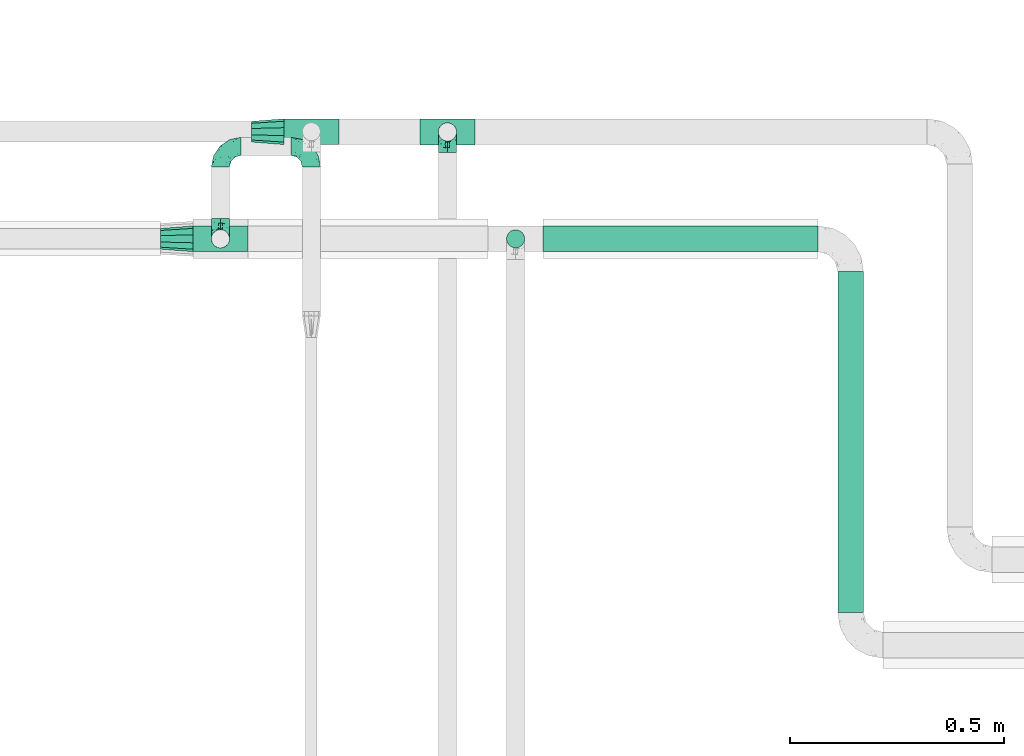
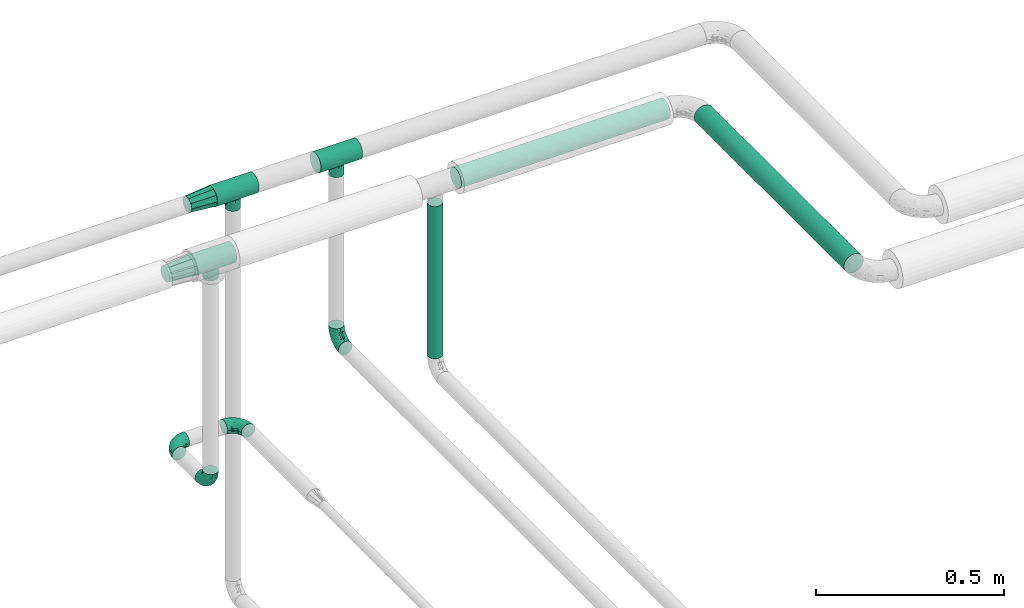
# One storey, part 581 of 827: 9 flow fittings, 3 flow segments.
"""IFC2X3 building model written with IfcOpenShell, lengths in millimetres."""

from ifc_helpers import new_model, entity, si_unit, converted_unit, derived_unit, direction, frame, origin, origin_2d_with_axis, place, context, subcontext, project, spatial, circle, extrude, faceted_brep, source, transform, mapped, material, type_object, type_shapes, element, save


model = new_model("IFC2X3")

# Units and contexts
model_context = context("Model", 3, precision=0.01, world=origin(), true_north=direction((6.12303176911189e-17, 1.0)))
body_context = subcontext(model_context, "Body", "Model", "MODEL_VIEW")
ifc_project = project(units=[si_unit("LENGTHUNIT", "METRE", prefix="MILLI"), si_unit("AREAUNIT", "SQUARE_METRE"), si_unit("VOLUMEUNIT", "CUBIC_METRE"), converted_unit("PLANEANGLEUNIT", "DEGREE", entity("IfcRatioMeasure", 0.0174532925199433), si_unit("PLANEANGLEUNIT", "RADIAN"), dimensions=[0, 0, 0, 0, 0, 0, 0]), si_unit("MASSUNIT", "GRAM", prefix="KILO"), derived_unit("MASSDENSITYUNIT", [(si_unit("MASSUNIT", "GRAM", prefix="KILO"), 1), (si_unit("LENGTHUNIT", "METRE"), -3)]), derived_unit("MOMENTOFINERTIAUNIT", [(si_unit("LENGTHUNIT", "METRE"), 4)]), si_unit("TIMEUNIT", "SECOND"), si_unit("FREQUENCYUNIT", "HERTZ"), si_unit("THERMODYNAMICTEMPERATUREUNIT", "DEGREE_CELSIUS"), derived_unit("THERMALTRANSMITTANCEUNIT", [(si_unit("MASSUNIT", "GRAM", prefix="KILO"), 1), (si_unit("THERMODYNAMICTEMPERATUREUNIT", "KELVIN"), -1), (si_unit("TIMEUNIT", "SECOND"), -3)]), derived_unit("VOLUMETRICFLOWRATEUNIT", [(si_unit("LENGTHUNIT", "METRE"), 3), (si_unit("TIMEUNIT", "SECOND"), -1)]), derived_unit("MASSFLOWRATEUNIT", [(si_unit("MASSUNIT", "GRAM", prefix="KILO"), 1), (si_unit("TIMEUNIT", "SECOND"), -1)]), derived_unit("ROTATIONALFREQUENCYUNIT", [(si_unit("TIMEUNIT", "SECOND"), -1)]), si_unit("ELECTRICCURRENTUNIT", "AMPERE"), si_unit("ELECTRICVOLTAGEUNIT", "VOLT"), si_unit("POWERUNIT", "WATT"), si_unit("FORCEUNIT", "NEWTON", prefix="KILO"), si_unit("ILLUMINANCEUNIT", "LUX"), si_unit("LUMINOUSFLUXUNIT", "LUMEN"), si_unit("LUMINOUSINTENSITYUNIT", "CANDELA"), derived_unit("USERDEFINED", [(si_unit("MASSUNIT", "GRAM", prefix="KILO"), -1), (si_unit("LENGTHUNIT", "METRE"), -2), (si_unit("TIMEUNIT", "SECOND"), 3), (si_unit("LUMINOUSFLUXUNIT", "LUMEN"), 1)]), derived_unit("LINEARVELOCITYUNIT", [(si_unit("LENGTHUNIT", "METRE"), 1), (si_unit("TIMEUNIT", "SECOND"), -1)]), si_unit("PRESSUREUNIT", "PASCAL"), derived_unit("USERDEFINED", [(si_unit("LENGTHUNIT", "METRE"), -2), (si_unit("MASSUNIT", "GRAM", prefix="KILO"), 1), (si_unit("TIMEUNIT", "SECOND"), -2)]), derived_unit("LINEARFORCEUNIT", [(si_unit("MASSUNIT", "GRAM", prefix="KILO"), 1), (si_unit("LENGTHUNIT", "METRE"), 1), (si_unit("TIMEUNIT", "SECOND"), -2), (si_unit("LENGTHUNIT", "METRE"), -1)]), derived_unit("PLANARFORCEUNIT", [(si_unit("MASSUNIT", "GRAM", prefix="KILO"), 1), (si_unit("LENGTHUNIT", "METRE"), 1), (si_unit("TIMEUNIT", "SECOND"), -2), (si_unit("LENGTHUNIT", "METRE"), -2)])], contexts=[model_context])

# Site, building, storey
site_placement = place(None, origin())
site = spatial("IfcSite", under=ifc_project, at=site_placement, CompositionType="ELEMENT")
building_placement = place(site_placement, origin())
building = spatial("IfcBuilding", under=site, at=building_placement, CompositionType="ELEMENT")
storey_placement = place(building_placement, frame((0.0, 0.0, 28200.0)))
storey = spatial("IfcBuildingStorey", under=building, at=storey_placement, Name="08", CompositionType="ELEMENT", Elevation=28200.0)

# Flow segments
pipe_segment_type = type_object("IfcPipeSegmentType", PredefinedType="NOTDEFINED")
flow_segment_1_placement = place(storey_placement, frame((15824.94, 18731.38, 2968.4)))
element("IfcFlowSegment", 1, at=flow_segment_1_placement, inside=storey, type_object=pipe_segment_type, context=body_context, shape_type="SweptSolid", body=[
    extrude(circle(Radius=30.0, at=origin_2d_with_axis()), frame((0.0, 31.6, 31.6), z_axis=(1.0, 0.0, 0.0), x_axis=(0.0, -1.0, 0.0)), (0.0, 0.0, 1.0), 643.229003793408),
])
flow_segment_2_placement = place(storey_placement, frame((16512.58, 17888.97, 2968.4)))
element("IfcFlowSegment", 2, at=flow_segment_2_placement, inside=storey, type_object=pipe_segment_type, context=body_context, shape_type="SweptSolid", body=[
    extrude(circle(Radius=30.0, at=origin_2d_with_axis()), frame((31.6, 0.0, 31.6), z_axis=(0.0, 1.0, 0.0), x_axis=(-1.0, 0.0, 0.0)), (0.0, 0.0, 1.0), 798.000000000022),
])
flow_segment_3_placement = place(storey_placement, frame((15738.2, 18740.23, 2448.01)))
element("IfcFlowSegment", 3, at=flow_segment_3_placement, inside=storey, type_object=pipe_segment_type, context=body_context, shape_type="SweptSolid", body=[
    extrude(circle(Radius=21.15, at=origin_2d_with_axis()), frame((22.75, 22.75, 0.0)), (0.0, 0.0, 1.0), 494.989664275865),
])

# Flow fittings
ifc_material = material()
pipe_fitting_type_1 = type_object("IfcPipeFittingType", Name="ADSK_1", PredefinedType="NOTDEFINED", material=ifc_material)
shared_shape_1 = source(origin(), body_context, "Body", "Brep", [
    faceted_brep([(-48.0, 10.6, -18.36), (-48.0, 5.49, -20.48), (-48.0, 0.0, -21.2), (-48.0, -5.49, -20.48), (-48.0, -10.6, -18.36), (-48.0, -14.99, -14.99), (-48.0, -18.36, -10.6), (-48.0, -20.48, -5.49), (-48.0, -21.2, 0.0), (-48.0, -20.48, 5.49), (-48.0, -18.36, 10.6), (-48.0, -14.99, 14.99), (-48.0, -10.6, 18.36), (-48.0, -5.49, 20.48), (-48.0, 0.0, 21.2), (-48.0, 5.49, 20.48), (-48.0, 10.6, 18.36), (-48.0, 14.99, 14.99), (-48.0, 18.36, 10.6), (-48.0, 20.48, 5.49), (-48.0, 21.2, 0.0), (-48.0, 20.48, -5.49), (-48.0, 18.36, -10.6), (-48.0, 14.99, -14.99), (0.0, 48.0, -21.2), (-5.49, 48.0, -20.48), (-10.6, 48.0, -18.36), (-14.99, 48.0, -14.99), (-18.36, 48.0, -10.6), (-20.48, 48.0, -5.49), (-21.2, 48.0, 0.0), (-20.48, 48.0, 5.49), (-18.36, 48.0, 10.6), (-14.99, 48.0, 14.99), (-10.6, 48.0, 18.36), (-5.49, 48.0, 20.48), (0.0, 48.0, 21.2), (5.49, 48.0, 20.48), (10.6, 48.0, 18.36), (14.99, 48.0, 14.99), (18.36, 48.0, 10.6), (20.48, 48.0, 5.49), (21.2, 48.0, 0.0), (20.48, 48.0, -5.49), (18.36, 48.0, -10.6), (14.99, 48.0, -14.99), (10.6, 48.0, -18.36), (5.49, 48.0, -20.48), (-35.25, -16.22, 12.01), (-34.76, -18.57, 0.0), (-20.87, -12.37, 10.9), (-31.49, -11.78, 15.9), (-37.0, -2.58, 20.86), (-33.89, 3.62, 21.15), (-31.81, -18.14, 6.76), (-5.78, 5.78, 17.67), (-19.42, -4.1, 17.86), (-9.6, -3.39, 13.73), (-35.44, -7.73, 19.13), (11.78, 31.49, 15.9), (-5.93, -5.46, 6.95), (-18.45, -13.78, 5.46), (-10.29, -8.43, 0.0), (-24.6, 0.55, 20.62), (-37.28, 17.94, 13.81), (-33.38, 22.85, 9.59), (-41.46, 20.06, 8.75), (-29.51, 20.45, 15.16), (-15.04, 10.79, 21.13), (-7.08, 16.98, 20.93), (-8.39, 23.51, 21.15), (-40.86, 13.03, 17.26), (-8.05, 41.26, 19.83), (-3.21, 35.97, 21.14), (8.53, 19.66, 14.74), (4.1, 19.42, 17.86), (-37.72, 22.66, 4.78), (-37.07, 8.58, 19.98), (-13.0, 5.43, 19.97), (-3.78, 13.93, 19.7), (3.02, 8.69, 13.43), (-2.27, -0.05, 10.65), (6.22, 6.99, 7.09), (-22.25, 34.6, 9.45), (18.14, 31.81, 6.76), (16.22, 35.25, 12.01), (12.37, 20.87, 10.9), (7.73, 35.44, 19.13), (-21.52, -15.93, 0.0), (2.58, 37.0, 20.86), (18.57, 34.76, 0.0), (13.78, 18.45, 5.46), (15.93, 21.52, 0.0), (-20.03, -8.54, 14.9), (-28.6, 28.6, 5.16), (-24.79, 34.6, 0.0), (-34.6, 24.79, 0.0), (-22.81, 37.41, 4.68), (-23.36, 26.33, 14.79), (-13.68, 37.05, 17.49), (-17.72, 38.12, 13.73), (-26.25, 27.3, 11.24), (-9.71, 32.34, 20.14), (-17.26, 25.6, 18.71), (-26.33, 9.99, 20.77), (-24.06, 6.05, 21.2), (-25.02, 15.46, 19.56), (-24.3, 20.72, 17.57), (-31.95, 15.23, 17.8), (-13.53, 24.7, 20.21), (-17.6, 17.6, 20.6), (-0.55, 24.6, 20.62), (-11.41, -7.48, 10.43), (0.93, -0.93, 0.0), (8.43, 10.29, 0.0), (-11.41, -7.48, -10.43), (-20.1, -8.84, -14.66), (-9.6, -3.39, -13.73), (7.73, 35.44, -19.13), (4.1, 19.42, -17.86), (-0.55, 24.6, -20.62), (-38.12, 17.72, -13.73), (-37.05, 13.68, -17.49), (-32.34, 9.71, -20.14), (-41.26, 8.05, -19.83), (-37.41, 22.81, -4.68), (-23.51, 8.39, -21.15), (-35.97, 3.21, -21.14), (-28.6, 28.6, -5.16), (-31.81, -18.14, -6.76), (-18.45, -13.78, -5.46), (-25.6, 17.26, -18.71), (-19.42, -4.1, -17.86), (-17.94, 37.28, -13.81), (-22.85, 33.38, -9.59), (-20.06, 41.46, -8.75), (-31.49, -11.78, -15.9), (-35.25, -16.22, -12.01), (8.53, 19.66, -14.74), (11.78, 31.49, -15.9), (-9.99, 26.33, -20.77), (-6.05, 24.06, -21.2), (-10.79, 15.04, -21.13), (-37.0, -2.58, -20.86), (-16.98, 7.08, -20.93), (-5.43, 13.0, -19.97), (-13.93, 3.78, -19.7), (-20.87, -12.37, -10.9), (-26.33, 23.36, -14.79), (-22.66, 37.72, -4.78), (13.78, 18.45, -5.46), (18.14, 31.81, -6.76), (-15.46, 25.02, -19.56), (-20.72, 24.3, -17.57), (16.22, 35.25, -12.01), (-13.03, 40.86, -17.26), (-8.58, 37.07, -19.98), (2.58, 37.0, -20.86), (-3.62, 33.89, -21.15), (-34.6, 22.25, -9.45), (6.22, 6.99, -7.09), (-20.45, 29.51, -15.16), (-35.44, -7.73, -19.13), (12.37, 20.87, -10.9), (-27.3, 26.25, -11.24), (-15.23, 31.95, -17.8), (-24.7, 13.53, -20.21), (-24.6, 0.55, -20.62), (-5.78, 5.78, -17.67), (-17.6, 17.6, -20.6), (3.02, 8.69, -13.43), (-5.93, -5.46, -6.95), (-2.27, -0.05, -10.65)], [[[0, 1, 2, 3, 4, 5, 6, 7, 8, 9, 10, 11, 12, 13, 14, 15, 16, 17, 18, 19, 20, 21, 22, 23]], [[24, 25, 26, 27, 28, 29, 30, 31, 32, 33, 34, 35, 36, 37, 38, 39, 40, 41, 42, 43, 44, 45, 46, 47]], [[10, 48, 11]], [[9, 8, 49]], [[48, 50, 51]], [[14, 52, 53]], [[10, 54, 48]], [[9, 54, 10]], [[55, 56, 57]], [[51, 12, 11]], [[51, 58, 12]], [[59, 39, 38]], [[60, 61, 62]], [[58, 56, 63]], [[64, 65, 66]], [[67, 65, 64]], [[68, 69, 70]], [[16, 71, 17]], [[13, 52, 14]], [[35, 72, 73]], [[14, 53, 15]], [[17, 64, 18]], [[74, 59, 75]], [[20, 19, 76]], [[66, 19, 18]], [[77, 15, 53]], [[15, 77, 16]], [[69, 78, 79]], [[80, 81, 82]], [[32, 31, 83]], [[84, 85, 86]], [[59, 87, 75]], [[61, 54, 88]], [[36, 89, 37]], [[84, 41, 40]], [[36, 35, 73]], [[90, 41, 84]], [[40, 39, 85]], [[12, 58, 13]], [[85, 84, 40]], [[91, 84, 86]], [[84, 92, 90]], [[87, 38, 37]], [[93, 56, 51]], [[65, 94, 76]], [[94, 95, 96]], [[84, 91, 92]], [[95, 97, 30]], [[98, 99, 100]], [[76, 94, 96]], [[101, 98, 83]], [[100, 99, 33]], [[102, 70, 73]], [[103, 102, 99]], [[94, 97, 95]], [[72, 99, 102]], [[72, 35, 34]], [[34, 33, 99]], [[9, 49, 54]], [[87, 59, 38]], [[104, 105, 68]], [[106, 103, 107]], [[106, 77, 104]], [[71, 64, 17]], [[108, 107, 67]], [[33, 32, 100]], [[109, 103, 110]], [[102, 109, 70]], [[89, 73, 111]], [[50, 48, 54]], [[51, 11, 48]], [[56, 58, 51]], [[88, 54, 49]], [[52, 58, 63]], [[50, 112, 93]], [[56, 55, 78]], [[39, 59, 85]], [[86, 85, 59]], [[89, 87, 37]], [[42, 41, 90]], [[111, 79, 75]], [[111, 75, 87]], [[75, 55, 80]], [[104, 77, 53]], [[71, 77, 108]], [[32, 83, 100]], [[98, 100, 83]], [[99, 98, 103]], [[106, 107, 108]], [[68, 70, 110]], [[111, 73, 70]], [[68, 110, 104]], [[68, 63, 78]], [[57, 93, 112]], [[80, 55, 57]], [[61, 50, 54]], [[80, 82, 86]], [[81, 57, 112]], [[74, 86, 59]], [[60, 113, 82]], [[82, 114, 91]], [[101, 94, 65]], [[97, 94, 83]], [[73, 89, 36]], [[87, 89, 111]], [[58, 52, 13]], [[53, 52, 63]], [[104, 53, 105]], [[106, 104, 110]], [[20, 76, 96]], [[76, 19, 66]], [[103, 106, 110]], [[77, 106, 108]], [[103, 98, 107]], [[67, 107, 98]], [[67, 98, 101]], [[108, 67, 64]], [[53, 63, 105]], [[63, 68, 105]], [[83, 31, 97]], [[30, 97, 31]], [[62, 113, 60]], [[112, 61, 60]], [[61, 88, 62]], [[86, 82, 91]], [[56, 78, 63]], [[114, 82, 113]], [[114, 92, 91]], [[79, 78, 55]], [[75, 79, 55]], [[69, 79, 111]], [[70, 69, 111]], [[78, 69, 68]], [[77, 71, 16]], [[64, 71, 108]], [[64, 66, 18]], [[76, 66, 65]], [[99, 72, 34]], [[73, 72, 102]], [[94, 101, 83]], [[67, 101, 65]], [[75, 80, 74]], [[80, 86, 74]], [[70, 109, 110]], [[102, 103, 109]], [[50, 93, 51]], [[57, 56, 93]], [[61, 112, 50]], [[81, 112, 60]], [[82, 81, 60]], [[80, 57, 81]], [[115, 116, 117]], [[118, 119, 120]], [[121, 122, 23]], [[123, 124, 122]], [[96, 125, 20]], [[123, 126, 127]], [[128, 96, 95]], [[129, 130, 88]], [[123, 122, 131]], [[116, 132, 117]], [[133, 134, 135]], [[0, 124, 1]], [[5, 136, 137]], [[138, 119, 139]], [[129, 88, 49]], [[140, 141, 142]], [[6, 5, 137]], [[46, 118, 47]], [[143, 3, 2]], [[144, 145, 146]], [[6, 129, 7]], [[129, 137, 147]], [[127, 2, 1]], [[148, 122, 121]], [[128, 125, 96]], [[134, 128, 149]], [[95, 149, 128]], [[150, 151, 92]], [[30, 29, 149]], [[152, 131, 153]], [[27, 133, 28]], [[154, 45, 44]], [[136, 5, 4]], [[27, 26, 155]], [[156, 26, 25]], [[24, 157, 158]], [[24, 47, 157]], [[22, 21, 159]], [[160, 150, 114]], [[134, 133, 161]], [[142, 144, 126]], [[46, 139, 118]], [[162, 136, 4]], [[156, 25, 158]], [[1, 124, 127]], [[115, 147, 116]], [[45, 154, 139]], [[139, 46, 45]], [[154, 163, 139]], [[162, 4, 3]], [[42, 90, 43]], [[130, 129, 147]], [[49, 7, 129]], [[43, 151, 44]], [[0, 23, 122]], [[24, 158, 25]], [[136, 162, 132]], [[135, 29, 28]], [[43, 90, 151]], [[164, 148, 159]], [[152, 156, 140]], [[155, 133, 27]], [[165, 153, 161]], [[23, 22, 121]], [[123, 131, 166]], [[123, 166, 126]], [[143, 127, 167]], [[147, 137, 136]], [[8, 7, 49]], [[129, 6, 137]], [[143, 162, 3]], [[167, 146, 132]], [[167, 132, 162]], [[132, 168, 117]], [[44, 151, 154]], [[92, 151, 90]], [[163, 154, 151]], [[119, 118, 139]], [[157, 118, 120]], [[138, 139, 163]], [[119, 168, 145]], [[140, 156, 158]], [[155, 156, 165]], [[22, 159, 121]], [[148, 121, 159]], [[122, 148, 131]], [[152, 153, 165]], [[142, 126, 169]], [[167, 127, 126]], [[142, 169, 140]], [[142, 120, 145]], [[168, 170, 117]], [[160, 171, 172]], [[115, 172, 171]], [[171, 62, 130]], [[119, 170, 168]], [[170, 163, 160]], [[150, 163, 151]], [[113, 171, 160]], [[164, 128, 134]], [[125, 128, 159]], [[127, 143, 2]], [[162, 143, 167]], [[118, 157, 47]], [[158, 157, 120]], [[140, 158, 141]], [[152, 140, 169]], [[30, 149, 95]], [[149, 29, 135]], [[131, 152, 169]], [[156, 152, 165]], [[131, 148, 153]], [[161, 153, 148]], [[161, 148, 164]], [[165, 161, 133]], [[158, 120, 141]], [[120, 142, 141]], [[159, 21, 125]], [[20, 125, 21]], [[115, 130, 147]], [[114, 113, 160]], [[62, 171, 113]], [[62, 88, 130]], [[160, 163, 150]], [[150, 92, 114]], [[119, 145, 120]], [[146, 145, 168]], [[132, 146, 168]], [[144, 146, 167]], [[126, 144, 167]], [[145, 144, 142]], [[156, 155, 26]], [[133, 155, 165]], [[133, 135, 28]], [[149, 135, 134]], [[122, 124, 0]], [[127, 124, 123]], [[128, 164, 159]], [[161, 164, 134]], [[163, 170, 138]], [[170, 119, 138]], [[131, 169, 166]], [[126, 166, 169]], [[147, 136, 116]], [[132, 116, 136]], [[172, 115, 117]], [[130, 115, 171]], [[117, 170, 172]], [[160, 172, 170]]]),
])
type_shapes(pipe_fitting_type_1, [shared_shape_1])
for number, where, z_axis, x_axis, name in (
    (4, (15601.55, 19012.8, 2402.06), (-1.0, 0.0, 0.0), (0.0, 0.0, -1.0), "ADSK_1"),
    (5, (15070.9, 18762.97, 2265.46), (1.0, 0.0, 0.0), (0.0, 0.0, -1.0), "ADSK_1"),
    (6, (15070.9, 18979.12, 2265.46), (0.0, 0.0, 1.0), (-1.0, 0.0, 0.0), "ADSK_1"),
    (7, (15283.51, 18979.12, 2265.46), (0.0, 0.0, 1.0), (0.0, 1.0, 0.0), "ADSK_1"),
):
    element("IfcFlowFitting", number, at=place(storey_placement, frame(where, z_axis=z_axis, x_axis=x_axis)), inside=storey, type_object=pipe_fitting_type_1, material=ifc_material, Name=name, ObjectType="ADSK_1", context=body_context, shape_type="MappedRepresentation", body=[
        mapped(shared_shape_1, transform((0.0, 0.0, 0.0), scale=1.0)),
    ])
pipe_fitting_type_2 = type_object("IfcPipeFittingType", Name="ADSK_1", PredefinedType="NOTDEFINED", material=ifc_material)
shared_shape_2 = source(origin(), body_context, "Body", "Brep", [
    faceted_brep([(-64.0, 15.07, -26.11), (-64.0, 7.8, -29.12), (-64.0, 0.0, -30.15), (-64.0, -7.8, -29.12), (-64.0, -15.08, -26.11), (-64.0, -21.32, -21.32), (-64.0, -26.11, -15.08), (-64.0, -29.12, -7.8), (-64.0, -30.15, 0.0), (-64.0, -29.12, 7.8), (-64.0, -26.11, 15.07), (-64.0, -21.32, 21.32), (-64.0, -15.08, 26.11), (-64.0, -7.8, 29.12), (-64.0, 0.0, 30.15), (-64.0, 7.8, 29.12), (-64.0, 15.07, 26.11), (-64.0, 21.32, 21.32), (-64.0, 26.11, 15.07), (-64.0, 29.12, 7.8), (-64.0, 30.15, 0.0), (-64.0, 29.12, -7.8), (-64.0, 26.11, -15.08), (-64.0, 21.32, -21.32), (64.0, 0.0, -30.15), (64.0, 7.8, -29.12), (64.0, 15.07, -26.11), (64.0, 21.32, -21.32), (64.0, 26.11, -15.08), (64.0, 29.12, -7.8), (64.0, 30.15, 0.0), (64.0, 29.12, 7.8), (64.0, 26.11, 15.07), (64.0, 21.32, 21.32), (64.0, 15.07, 26.11), (64.0, 7.8, 29.12), (64.0, 0.0, 30.15), (64.0, -7.8, 29.12), (64.0, -15.08, 26.11), (64.0, -21.32, 21.32), (64.0, -26.11, 15.07), (64.0, -29.12, 7.8), (64.0, -30.15, 0.0), (64.0, -29.12, -7.8), (64.0, -26.11, -15.08), (64.0, -21.32, -21.32), (64.0, -15.08, -26.11), (64.0, -7.8, -29.12), (19.84, -29.21, 7.47), (20.52, -29.68, 3.73), (21.2, -30.15, 0.0), (16.14, -26.84, 13.74), (10.7, -23.96, 18.3), (3.81, -21.77, 20.85), (-3.82, -21.77, 20.85), (0.0, -21.77, 20.85), (-21.2, -30.15, 0.0), (-20.52, -29.68, 3.73), (-19.84, -29.21, 7.47), (-16.15, -26.84, 13.74), (-10.7, -23.96, 18.3), (3.81, -21.77, -20.85), (10.7, -23.96, -18.3), (16.14, -26.84, -13.74), (0.0, -21.77, -20.85), (-3.82, -21.77, -20.85), (19.84, -29.21, -7.47), (20.52, -29.68, -3.73), (-10.7, -23.96, -18.3), (-16.15, -26.84, -13.74), (-19.84, -29.21, -7.47), (-20.52, -29.68, -3.73), (0.0, -57.0, -21.2), (5.49, -57.0, -20.48), (10.6, -57.0, -18.36), (14.99, -57.0, -14.99), (18.36, -57.0, -10.6), (20.48, -57.0, -5.49), (21.2, -57.0, 0.0), (20.48, -57.0, 5.49), (18.36, -57.0, 10.6), (14.99, -57.0, 14.99), (10.6, -57.0, 18.36), (5.49, -57.0, 20.48), (0.0, -57.0, 21.2), (-5.49, -57.0, 20.48), (-10.6, -57.0, 18.36), (-14.99, -57.0, 14.99), (-18.36, -57.0, 10.6), (-20.48, -57.0, 5.49), (-21.2, -57.0, 0.0), (-20.48, -57.0, -5.49), (-18.36, -57.0, -10.6), (-14.99, -57.0, -14.99), (-10.6, -57.0, -18.36), (-5.49, -57.0, -20.48)], [[[0, 1, 2, 3, 4, 5, 6, 7, 8, 9, 10, 11, 12, 13, 14, 15, 16, 17, 18, 19, 20, 21, 22, 23]], [[24, 25, 26, 27, 28, 29, 30, 31, 32, 33, 34, 35, 36, 37, 38, 39, 40, 41, 42, 43, 44, 45, 46, 47]], [[42, 41, 48]], [[42, 48, 49, 50]], [[41, 51, 48]], [[40, 39, 52]], [[52, 51, 40]], [[53, 52, 39]], [[12, 54, 55, 53]], [[40, 51, 41]], [[8, 56, 57, 58]], [[9, 8, 58]], [[58, 59, 9]], [[60, 54, 11]], [[60, 10, 59]], [[10, 60, 11]], [[59, 10, 9]], [[11, 54, 12]], [[53, 39, 38]], [[14, 13, 37, 36]], [[13, 12, 38, 37]], [[15, 14, 36, 35]], [[32, 31, 19, 18]], [[17, 16, 34, 33]], [[18, 17, 33, 32]], [[35, 34, 16, 15]], [[20, 19, 31, 30]], [[38, 12, 53]], [[29, 28, 22, 21]], [[28, 27, 23, 22]], [[30, 29, 21, 20]], [[24, 47, 3, 2]], [[1, 0, 26, 25]], [[2, 1, 25, 24]], [[27, 26, 0, 23]], [[4, 3, 47, 46]], [[46, 61, 4]], [[45, 44, 62]], [[62, 61, 45]], [[44, 63, 62]], [[4, 61, 64, 65]], [[43, 42, 66]], [[66, 63, 43]], [[42, 50, 67, 66]], [[43, 63, 44]], [[65, 68, 5]], [[6, 5, 68]], [[68, 69, 6]], [[5, 4, 65]], [[69, 70, 7]], [[70, 8, 7]], [[8, 70, 71, 56]], [[69, 7, 6]], [[61, 46, 45]], [[72, 73, 74, 75, 76, 77, 78, 79, 80, 81, 82, 83, 84, 85, 86, 87, 88, 89, 90, 91, 92, 93, 94, 95]], [[57, 90, 89]], [[49, 78, 50]], [[60, 87, 86]], [[84, 54, 85]], [[49, 48, 79]], [[60, 86, 85]], [[89, 58, 57]], [[56, 90, 57]], [[58, 89, 88]], [[58, 88, 59]], [[87, 59, 88]], [[87, 60, 59]], [[85, 54, 60]], [[84, 53, 55, 54]], [[52, 83, 82]], [[81, 52, 82]], [[48, 80, 79]], [[81, 80, 51]], [[53, 84, 83]], [[83, 52, 53]], [[52, 81, 51]], [[51, 80, 48]], [[78, 49, 79]], [[77, 67, 78]], [[63, 76, 75]], [[72, 61, 73]], [[77, 66, 67]], [[76, 66, 77]], [[74, 62, 75]], [[67, 50, 78]], [[66, 76, 63]], [[62, 73, 61]], [[62, 63, 75]], [[72, 65, 64, 61]], [[62, 74, 73]], [[71, 70, 91]], [[68, 95, 94]], [[93, 68, 94]], [[70, 92, 91]], [[93, 92, 69]], [[65, 72, 95]], [[95, 68, 65]], [[68, 93, 69]], [[69, 92, 70]], [[90, 71, 91]], [[71, 90, 56]]]),
])
type_shapes(pipe_fitting_type_2, [shared_shape_2])
for number, where, z_axis, x_axis, name in (
    (8, (15283.51, 19013.47, 3000.0), (0.0, 1.0, 0.0), (-1.0, 0.0, 0.0), "ADSK_1"),
    (9, (15070.9, 18762.97, 3000.0), (0.0, 1.0, 0.0), (-1.0, 0.0, 0.0), "ADSK_1"),
    (10, (15601.55, 19012.8, 2999.06), (0.0, 1.0, 0.0), (-1.0, 0.0, 0.0), "ADSK_1"),
):
    element("IfcFlowFitting", number, at=place(storey_placement, frame(where, z_axis=z_axis, x_axis=x_axis)), inside=storey, type_object=pipe_fitting_type_2, material=ifc_material, Name=name, ObjectType="ADSK_1", context=body_context, shape_type="MappedRepresentation", body=[
        mapped(shared_shape_2, transform((0.0, 0.0, 0.0), scale=1.0)),
    ])
pipe_fitting_type_3 = type_object("IfcPipeFittingType", Name="ADSK_1", PredefinedType="NOTDEFINED", material=ifc_material)
shared_shape_3 = source(origin(), body_context, "Body", "Brep", [
    faceted_brep([(76.0, 7.46, 22.97), (76.0, 0.0, 22.97), (76.0, -7.46, 22.97), (76.0, -13.5, 18.58), (76.0, -19.54, 14.2), (76.0, -21.84, 7.1), (76.0, -24.15, 0.0), (76.0, -21.84, -7.1), (76.0, -19.54, -14.2), (76.0, -13.5, -18.58), (76.0, -7.46, -22.97), (76.0, 0.0, -22.97), (76.0, 7.46, -22.97), (76.0, 13.5, -18.58), (76.0, 19.54, -14.2), (76.0, 21.84, -7.1), (76.0, 24.15, 0.0), (76.0, 21.84, 7.1), (76.0, 19.54, 14.2), (76.0, 13.5, 18.58), (0.0, -9.32, 28.67), (0.0, 0.0, 28.67), (0.0, 9.32, 28.67), (0.0, 16.85, 23.2), (0.0, 24.39, 17.72), (0.0, 27.27, 8.86), (0.0, 30.15, 0.0), (0.0, 28.24, -5.87), (0.0, 26.33, -11.75), (0.0, 24.39, -17.72), (0.0, 16.85, -23.2), (0.0, 9.32, -28.67), (0.0, 0.0, -28.67), (0.0, -9.32, -28.67), (0.0, -16.85, -23.2), (0.0, -24.39, -17.72), (0.0, -27.27, -8.86), (0.0, -30.15, 0.0), (0.0, -28.24, 5.87), (0.0, -26.33, 11.75), (0.0, -24.39, 17.72), (0.0, -16.85, 23.2)], [[[0, 1, 2, 3, 4, 5, 6, 7, 8, 9, 10, 11, 12, 13, 14, 15, 16, 17, 18, 19]], [[20, 21, 22, 23, 24, 25, 26, 27, 28, 29, 30, 31, 32, 33, 34, 35, 36, 37, 38, 39, 40, 41]], [[35, 8, 7, 6, 37, 36]], [[10, 33, 32, 31, 12, 11]], [[10, 9, 8, 35, 34, 33]], [[15, 14, 29, 28, 27, 26, 16]], [[31, 30, 29, 14, 13, 12]], [[24, 18, 17, 16, 26, 25]], [[0, 22, 21, 20, 2, 1]], [[0, 19, 18, 24, 23, 22]], [[5, 4, 40, 39, 38, 37, 6]], [[20, 41, 40, 4, 3, 2]]]),
])
type_shapes(pipe_fitting_type_3, [shared_shape_3])
for number, where, z_axis, x_axis, name in (
    (11, (15219.51, 19013.47, 3000.0), (0.0, 0.0, 1.0), (-1.0, 0.0, 0.0), "ADSK_1"),
    (12, (15006.9, 18762.97, 3000.0), (0.0, 0.0, 1.0), (-1.0, 0.0, 0.0), "ADSK_1"),
):
    element("IfcFlowFitting", number, at=place(storey_placement, frame(where, z_axis=z_axis, x_axis=x_axis)), inside=storey, type_object=pipe_fitting_type_3, material=ifc_material, Name=name, ObjectType="ADSK_1", context=body_context, shape_type="MappedRepresentation", body=[
        mapped(shared_shape_3, transform((0.0, 0.0, 0.0), scale=1.0)),
    ])

save(model, "model.ifc")
